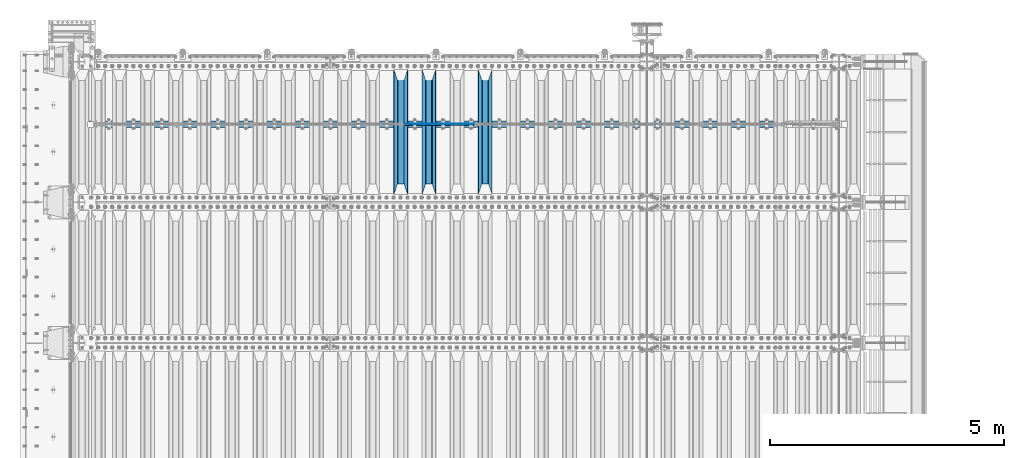
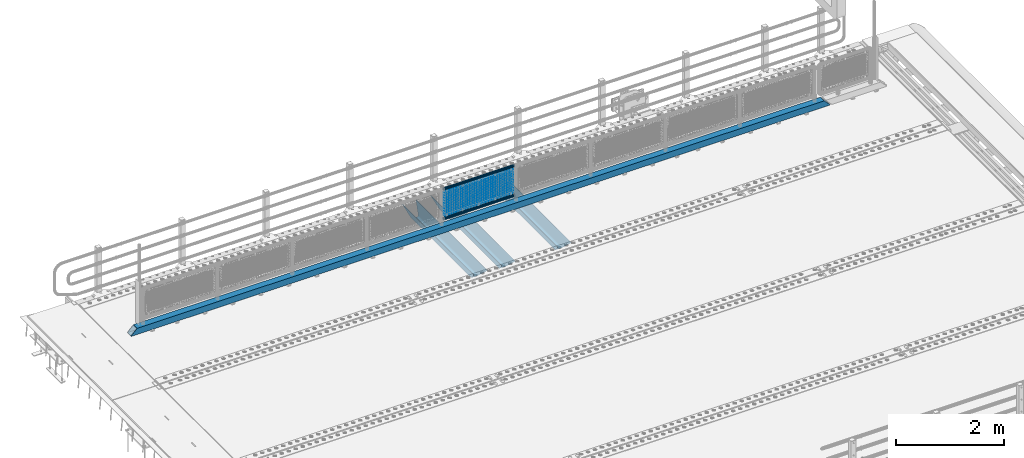
# One storey, part 122 of 257: 23 beams.
"""IFC2X3 building model written with IfcOpenShell, lengths in millimetres."""

import ifcopenshell
import ifcopenshell.guid

model = None  # the IFC model being written
_history = None  # IfcOwnerHistory: only IFC2X3 demands one
_inside = {}  # id of a spatial element -> (the spatial element, [elements in it])
_under = {}  # id of a project, library or spatial element -> (it, [spatial elements below it])
_declared = {}  # id of a project -> (the project, [libraries it declares])
_typed = {}  # id of a type object -> (the type object, [elements of that type])
_made_of = {}  # id of a material, layer set ... -> (it, [elements and type objects made of it])


def new_model(schema):
    """Start an empty IFC model of exactly this schema.

    Asked for "IFC4X3", IfcOpenShell would pick the latest addendum, in which some entities
    have other attributes; the version numbers below select the first issue.
    IFC2X3 requires an IfcOwnerHistory on every rooted entity: one is made here for all.
    """
    global model, _history
    if schema == "IFC4X3":
        model = ifcopenshell.file(schema_version=(4, 3, 0, 0))
    else:
        model = ifcopenshell.file(schema=schema)
    _inside.clear()
    _under.clear()
    _declared.clear()
    _typed.clear()
    _made_of.clear()
    _history = None
    if model.schema == "IFC2X3":
        org = make("IfcOrganization", Name="unknown")
        user = make(
            "IfcPersonAndOrganization",
            ThePerson=make("IfcPerson", FamilyName="unknown"),
            TheOrganization=org,
        )
        app = make(
            "IfcApplication",
            ApplicationDeveloper=org,
            Version="unknown",
            ApplicationFullName="unknown",
            ApplicationIdentifier="unknown",
        )
        _history = make(
            "IfcOwnerHistory",
            OwningUser=user,
            OwningApplication=app,
            ChangeAction="ADDED",
            CreationDate=0,
        )
    return model


def make(cls, **values):
    """One entity of the class cls with the attributes given. An attribute that is None is left unset."""
    return model.create_entity(
        cls, **{name: value for name, value in values.items() if value is not None}
    )


def rooted(cls, **values):
    """An entity with a GlobalId (a new one), such as an element, a storey or a relation."""
    return make(cls, GlobalId=ifcopenshell.guid.new(), OwnerHistory=_history, **values)


def si_unit(unit_type, name, prefix=None):
    """IfcSIUnit, for example si_unit("LENGTHUNIT", "METRE", prefix="MILLI")."""
    return make("IfcSIUnit", UnitType=unit_type, Prefix=prefix, Name=name)


def assignment(units):
    """IfcUnitAssignment: the units of a project."""
    return None if units is None else make("IfcUnitAssignment", Units=units)


def point(xyz):
    """IfcCartesianPoint."""
    return None if xyz is None else make("IfcCartesianPoint", Coordinates=xyz)


def direction(xyz):
    """IfcDirection."""
    return None if xyz is None else make("IfcDirection", DirectionRatios=xyz)


def frame(location, z_axis=None, x_axis=None):
    """IfcAxis2Placement3D, a coordinate frame: its origin and axes. An axis left out is left unset."""
    return make(
        "IfcAxis2Placement3D",
        Location=point(location),
        Axis=direction(z_axis),
        RefDirection=direction(x_axis),
    )


def origin_with_axes():
    """The frame at (0, 0, 0) with the z axis (0, 0, 1) and the x axis (1, 0, 0) written out."""
    return frame((0.0, 0.0, 0.0), z_axis=(0.0, 0.0, 1.0), x_axis=(1.0, 0.0, 0.0))


def place(relative_to, where):
    """IfcLocalPlacement: puts the frame where relative to a parent placement (None: the world)."""
    return make(
        "IfcLocalPlacement", PlacementRelTo=relative_to, RelativePlacement=where
    )


def context(
    kind, dimensions, precision=None, world=None, true_north=None, identifier=None
):
    """IfcGeometricRepresentationContext, for example the 3D "Model" context."""
    return make(
        "IfcGeometricRepresentationContext",
        ContextIdentifier=identifier,
        ContextType=kind,
        CoordinateSpaceDimension=dimensions,
        Precision=precision,
        WorldCoordinateSystem=world,
        TrueNorth=true_north,
    )


def subcontext(parent, identifier, kind, view, scale=None):
    """IfcGeometricRepresentationSubContext, for example "Body" below "Model"."""
    return make(
        "IfcGeometricRepresentationSubContext",
        ContextIdentifier=identifier,
        ContextType=kind,
        ParentContext=parent,
        TargetScale=scale,
        TargetView=view,
    )


def project(units=None, contexts=None):
    """IfcProject with its units and contexts."""
    return rooted(
        "IfcProject",
        Name="project",
        RepresentationContexts=contexts,
        UnitsInContext=assignment(units),
    )


def spatial(cls, under=None, at=None, **own):
    """A site, building, storey or space (cls), placed at a placement, below another one or the project."""
    s = rooted(cls, ObjectPlacement=at, **own)
    if under is not None:
        _under.setdefault(under.id(), (under, []))[1].append(s)
    return s


def faces_of(points, faces, orient=None, outer=None):
    """IfcFace entities. A face is a list of loops; a loop is a list of indices into points, from 0.

    orient and outer hold one flag for each loop. By default every Orientation is true, the
    first loop of a face is its IfcFaceOuterBound and the others are IfcFaceBound.
    """
    made = []
    for i, loops in enumerate(faces):
        bounds = []
        for j, loop in enumerate(loops):
            is_outer = j == 0 if outer is None else outer[i][j]
            bounds.append(
                make(
                    "IfcFaceOuterBound" if is_outer else "IfcFaceBound",
                    Bound=make("IfcPolyLoop", Polygon=[points[k] for k in loop]),
                    Orientation=True if orient is None else orient[i][j],
                )
            )
        made.append(make("IfcFace", Bounds=bounds))
    return made


def faceted_brep(points, faces, orient=None, outer=None, voids=None):
    """IfcFacetedBrep: a solid bounded by flat faces; with voids (closed shells), ...WithVoids."""
    shared = [point(p) for p in points]
    hull = make("IfcClosedShell", CfsFaces=faces_of(shared, faces, orient, outer))
    if voids is None:
        return make("IfcFacetedBrep", Outer=hull)
    return make(
        "IfcFacetedBrepWithVoids",
        Outer=hull,
        Voids=[
            make(cls, CfsFaces=faces_of(shared, fs, o, b)) for cls, fs, o, b in voids
        ],
    )


def shape(context_of_items, identifier, shape_type, items):
    """IfcShapeRepresentation: the items that make up one representation, for example the "Body"."""
    return make(
        "IfcShapeRepresentation",
        ContextOfItems=context_of_items,
        RepresentationIdentifier=identifier,
        RepresentationType=shape_type,
        Items=items,
    )


def material(Name=None, Category=None):
    """IfcMaterial."""
    return make("IfcMaterial", Name=Name, Category=Category)


def made_of(thing, what):
    """Note that an element or type object is made of a material, layer set ...; save() writes the relation."""
    if what is not None:
        _made_of.setdefault(what.id(), (what, []))[1].append(thing)
    return thing


def type_object(cls, material=None, **own):
    """A type object (cls), such as IfcWallType, which elements share."""
    return made_of(rooted(cls, **own), material)


def element(
    cls,
    number,
    at=None,
    inside=None,
    cuts=None,
    type_object=None,
    material=None,
    context=None,
    identifier="Body",
    shape_type=None,
    held_by="IfcProductDefinitionShape",
    body=None,
    shapes=None,
    **own,
):
    """One element of the class cls, such as IfcWall. Its Tag is "e" and its number.

    at: its placement. inside: the storey or other place that contains it. cuts: it is an
    opening in that element (IfcRelVoidsElement). A single representation is given by context,
    identifier, shape_type and body (its items); several are given by shapes. held_by: the class
    of the entity that holds the representations. save() writes the other relations.
    """
    e = rooted(cls, Tag="e%d" % number, ObjectPlacement=at, **own)
    if body is not None:
        shapes = [shape(context, identifier, shape_type, body)]
    if shapes is not None:
        e.Representation = make(held_by, Representations=shapes)
    if inside is not None:
        _inside.setdefault(inside.id(), (inside, []))[1].append(e)
    if cuts is not None:
        rooted(
            "IfcRelVoidsElement", RelatingBuildingElement=cuts, RelatedOpeningElement=e
        )
    if type_object is not None:
        _typed.setdefault(type_object.id(), (type_object, []))[1].append(e)
    return made_of(e, material)


def aggregate(whole, parts):
    """IfcRelAggregates: a whole, such as a stair, and the parts it consists of."""
    return rooted("IfcRelAggregates", RelatingObject=whole, RelatedObjects=parts)


def save(model, path):
    """Write the relations noted so far, then the file.

    IfcRelAggregates (storeys below a building ...), IfcRelContainedInSpatialStructure (elements
    in a storey), IfcRelDefinesByType, IfcRelAssociatesMaterial and IfcRelDeclares: one each for
    every whole, place, type object, material and project.
    """
    for whole, parts in _under.values():
        aggregate(whole, parts)
    for where, things in _inside.values():
        rooted(
            "IfcRelContainedInSpatialStructure",
            RelatedElements=things,
            RelatingStructure=where,
        )
    for kind, things in _typed.values():
        rooted("IfcRelDefinesByType", RelatedObjects=things, RelatingType=kind)
    for what, things in _made_of.values():
        rooted("IfcRelAssociatesMaterial", RelatedObjects=things, RelatingMaterial=what)
    for by, libraries in _declared.values():
        rooted("IfcRelDeclares", RelatingContext=by, RelatedDefinitions=libraries)
    model.write(path)


model = new_model("IFC2X3")

# Units and contexts
model_context = context("Model", 3, precision=1e-05, world=origin_with_axes())
body_context = subcontext(model_context, "Body", "Model", "MODEL_VIEW")
ifc_project = project(units=[si_unit("LENGTHUNIT", "METRE", prefix="MILLI"), si_unit("AREAUNIT", "SQUARE_METRE"), si_unit("VOLUMEUNIT", "CUBIC_METRE"), si_unit("MASSUNIT", "GRAM", prefix="KILO"), si_unit("TIMEUNIT", "SECOND"), si_unit("PLANEANGLEUNIT", "RADIAN"), si_unit("SOLIDANGLEUNIT", "STERADIAN"), si_unit("THERMODYNAMICTEMPERATUREUNIT", "DEGREE_CELSIUS"), si_unit("LUMINOUSINTENSITYUNIT", "LUMEN")], contexts=[model_context])

# Site, building, storey
site_placement = place(None, origin_with_axes())
site = spatial("IfcSite", under=ifc_project, at=site_placement, CompositionType="ELEMENT")
building_placement = place(site_placement, origin_with_axes())
building = spatial("IfcBuilding", under=site, at=building_placement, Name="Standard", CompositionType="ELEMENT")
storey_placement = place(building_placement, origin_with_axes())
storey = spatial("IfcBuildingStorey", under=building, at=storey_placement, Name="Undefined", CompositionType="ELEMENT", Elevation=0.0)

# Beams
ifc_material_1 = material(Name="STEEL/S355N")
beam_type_1 = type_object("IfcBeamType", PredefinedType="NOTDEFINED")
beam_1_placement = place(storey_placement, frame((51250.0, 9175.0, -115.0), z_axis=(0.0, 0.0, 1.0), x_axis=(0.0, 1.0, 0.0)))
element("IfcBeam", 1, at=beam_1_placement, inside=storey, type_object=beam_type_1, material=ifc_material_1, context=body_context, shape_type="Brep", body=[
    faceted_brep([(0.0, 150.0, 115.0), (0.0, 143.690000000002, 115.0), (2650.00000000297, 143.690000000002, 115.0), (2650.00000000297, 150.0, 115.0), (2650.00000000297, 142.059565218406, 110.0000000031), (2650.00000000297, 148.369565218403, 110.0000000031), (2441.90079219208, -80.1103600731149, -98.0992078077845), (2437.7588105432, -77.5672621345584, -102.241189456673), (2434.06523489746, -74.4080125315522, -105.934765102404), (2430.91086095089, -70.7102721255724, -109.089139048974), (2428.37322971128, -66.5649389910031, -111.626770288588), (2426.51472138055, -62.0739139532889, -113.485278619323), (2425.38102192091, -57.3475956567636, -114.618978078955), (2424.99999999987, -52.5021667386536, -115.0), (2424.99999999987, 52.5021667386536, -115.0), (2425.38102192091, 57.3475956567636, -114.618978078955), (2426.51472138055, 62.0739139532889, -113.485278619323), (2428.37322971128, 66.5649389910031, -111.626770288588), (2430.91086095089, 70.7102721255724, -109.089139048974), (2434.06523489746, 74.4080125315522, -105.934765102404), (2437.7588105432, 77.5672621345584, -102.241189456673), (2441.90079219208, 80.1103600731149, -98.0992078077846), (2446.38936140511, 81.9747917625791, -93.6106385947584), (2448.24948500409, 76.2713538057287, -91.7505149957729), (2444.62967112262, 74.76777986261, -95.3703288772456), (2441.28936334126, 72.7168944282894, -98.710636658607), (2438.31067330438, 70.1691124903809, -101.689326695487), (2435.76682334747, 67.1870637758839, -104.233176652398), (2433.72034654133, 63.8440531834931, -106.279653458539), (2432.22154950041, 60.2222587982324, -107.778450499454), (2431.30727574265, 56.4107117849126, -108.692724257221), (2430.99999999987, 52.5031078186876, -109.0), (2430.99999999987, -52.5031078186876, -109.0), (2431.30727574265, -56.4107117849126, -108.692724257221), (2432.22154950041, -60.2222587982324, -107.778450499454), (2433.72034654133, -63.8440531834931, -106.279653458539), (2435.76682334747, -67.1870637758839, -104.233176652398), (2438.31067330438, -70.1691124903809, -101.689326695487), (2441.28936334126, -72.7168944282894, -98.7106366586071), (2444.62967112262, -74.76777986261, -95.3703288772457), (2448.24948500409, -76.2713538057287, -91.7505149957729), (2650.00000000297, -142.059565218406, 110.0000000031), (2650.00000000297, -148.369565218403, 110.0000000031), (2446.38936140511, -81.9747917625791, -93.6106385947584), (2650.00000000297, -143.690000000002, 115.0), (2650.00000000297, -150.0, 115.0), (0.0, -143.690000000002, 115.0), (0.0, -150.0, 115.0), (0.0, -148.369565218258, 110.000000002662), (203.61063859742, -81.9747917625791, -93.6106385947584), (208.099207810447, -80.1103600731149, -98.0992078077845), (212.241189459335, -77.5672621345584, -102.241189456673), (215.934765105066, -74.4080125315522, -105.934765102404), (219.089139051636, -70.7102721255724, -109.089139048974), (221.626770291251, -66.5649389910031, -111.626770288588), (223.485278621985, -62.0739139532889, -113.485278619323), (224.618978081617, -57.3475956567636, -114.618978078955), (225.000000002662, -52.5021667386536, -115.0), (225.000000002662, 52.5021667386536, -115.0), (224.618978081617, 57.3475956567636, -114.618978078955), (223.485278621985, 62.0739139532889, -113.485278619323), (221.626770291251, 66.5649389910031, -111.626770288588), (219.089139051636, 70.7102721255724, -109.089139048974), (215.934765105066, 74.4080125315522, -105.934765102404), (212.241189459335, 77.5672621345584, -102.241189456673), (208.099207810447, 80.1103600731149, -98.0992078077846), (203.61063859742, 81.9747917625791, -93.6106385947584), (0.0, 148.369565218258, 110.000000002662), (0.0, 142.05956521826, 110.000000002662), (201.750514998435, 76.2713538057287, -91.7505149957729), (205.370328879908, 74.76777986261, -95.3703288772456), (208.710636661269, 72.7168944282894, -98.710636658607), (211.689326698149, 70.1691124903809, -101.689326695487), (214.233176655061, 67.1870637758839, -104.233176652398), (216.279653461201, 63.8440531834931, -106.279653458539), (217.778450502116, 60.2222587982324, -107.778450499454), (218.692724259884, 56.4107117849126, -108.692724257221), (219.000000002662, 52.5031078186876, -109.0), (219.000000002662, -52.5031078186876, -109.0), (218.692724259884, -56.4107117849126, -108.692724257221), (217.778450502116, -60.2222587982324, -107.778450499454), (216.279653461201, -63.8440531834931, -106.279653458539), (214.233176655061, -67.1870637758839, -104.233176652398), (211.689326698149, -70.1691124903809, -101.689326695487), (208.710636661269, -72.7168944282894, -98.7106366586071), (205.370328879908, -74.76777986261, -95.3703288772457), (201.750514998435, -76.2713538057287, -91.7505149957729), (0.0, -142.05956521826, 110.000000002662)], [[[0, 1, 2, 3]], [[3, 2, 4, 5]], [[6, 7, 8, 9, 10, 11, 12, 13, 14, 15, 16, 17, 18, 19, 20, 21, 22, 5, 4, 23, 24, 25, 26, 27, 28, 29, 30, 31, 32, 33, 34, 35, 36, 37, 38, 39, 40, 41, 42, 43]], [[44, 45, 42, 41]], [[46, 47, 45, 44]], [[43, 42, 45, 47, 48, 49]], [[6, 43, 49, 50]], [[7, 6, 50, 51]], [[8, 7, 51, 52]], [[9, 8, 52, 53]], [[10, 9, 53, 54]], [[11, 10, 54, 55]], [[12, 11, 55, 56]], [[13, 12, 56, 57]], [[14, 13, 57, 58]], [[15, 14, 58, 59]], [[16, 15, 59, 60]], [[17, 16, 60, 61]], [[18, 17, 61, 62]], [[19, 18, 62, 63]], [[20, 19, 63, 64]], [[21, 20, 64, 65]], [[22, 21, 65, 66]], [[0, 3, 5, 22, 66, 67]], [[1, 0, 67, 68]], [[23, 4, 2, 1, 68, 69]], [[24, 23, 69, 70]], [[25, 24, 70, 71]], [[26, 25, 71, 72]], [[27, 26, 72, 73]], [[28, 27, 73, 74]], [[29, 28, 74, 75]], [[30, 29, 75, 76]], [[31, 30, 76, 77]], [[32, 31, 77, 78]], [[33, 32, 78, 79]], [[34, 33, 79, 80]], [[35, 34, 80, 81]], [[36, 35, 81, 82]], [[37, 36, 82, 83]], [[38, 37, 83, 84]], [[39, 38, 84, 85]], [[40, 39, 85, 86]], [[46, 44, 41, 40, 86, 87]], [[47, 46, 87, 48]], [[86, 85, 84, 83, 82, 81, 80, 79, 78, 77, 76, 75, 74, 73, 72, 71, 70, 69, 68, 67, 66, 65, 64, 63, 62, 61, 60, 59, 58, 57, 56, 55, 54, 53, 52, 51, 50, 49, 48, 87]]]),
])
beam_2_placement = place(storey_placement, frame((50050.0, 9175.0, -115.0), z_axis=(0.0, 0.0, 1.0), x_axis=(0.0, 1.0, 0.0)))
element("IfcBeam", 2, at=beam_2_placement, inside=storey, type_object=beam_type_1, material=ifc_material_1, context=body_context, shape_type="Brep", body=[
    faceted_brep([(0.0, 150.0, 115.0), (0.0, 143.690000000002, 115.0), (2650.00000000297, 143.690000000002, 115.0), (2650.00000000297, 150.0, 115.0), (2650.00000000297, 142.059565218406, 110.0000000031), (2650.00000000297, 148.369565218403, 110.0000000031), (2441.90079219208, -80.1103600731149, -98.0992078077845), (2437.7588105432, -77.5672621345584, -102.241189456673), (2434.06523489746, -74.4080125315522, -105.934765102404), (2430.91086095089, -70.7102721255724, -109.089139048974), (2428.37322971128, -66.5649389910031, -111.626770288588), (2426.51472138055, -62.0739139532889, -113.485278619323), (2425.38102192091, -57.3475956567636, -114.618978078955), (2424.99999999987, -52.5021667386536, -115.0), (2424.99999999987, 52.5021667386536, -115.0), (2425.38102192091, 57.3475956567636, -114.618978078955), (2426.51472138055, 62.0739139532889, -113.485278619323), (2428.37322971128, 66.5649389910031, -111.626770288588), (2430.91086095089, 70.7102721255724, -109.089139048974), (2434.06523489746, 74.4080125315522, -105.934765102404), (2437.7588105432, 77.5672621345584, -102.241189456673), (2441.90079219208, 80.1103600731149, -98.0992078077846), (2446.38936140511, 81.9747917625791, -93.6106385947584), (2448.24948500409, 76.2713538057287, -91.7505149957729), (2444.62967112262, 74.76777986261, -95.3703288772456), (2441.28936334126, 72.7168944282894, -98.710636658607), (2438.31067330438, 70.1691124903809, -101.689326695487), (2435.76682334747, 67.1870637758839, -104.233176652398), (2433.72034654133, 63.8440531834931, -106.279653458539), (2432.22154950041, 60.2222587982324, -107.778450499454), (2431.30727574265, 56.4107117849126, -108.692724257221), (2430.99999999987, 52.5031078186876, -109.0), (2430.99999999987, -52.5031078186876, -109.0), (2431.30727574265, -56.4107117849126, -108.692724257221), (2432.22154950041, -60.2222587982324, -107.778450499454), (2433.72034654133, -63.8440531834931, -106.279653458539), (2435.76682334747, -67.1870637758839, -104.233176652398), (2438.31067330438, -70.1691124903809, -101.689326695487), (2441.28936334126, -72.7168944282894, -98.7106366586071), (2444.62967112262, -74.76777986261, -95.3703288772457), (2448.24948500409, -76.2713538057287, -91.7505149957729), (2650.00000000297, -142.059565218406, 110.0000000031), (2650.00000000297, -148.369565218403, 110.0000000031), (2446.38936140511, -81.9747917625791, -93.6106385947584), (2650.00000000297, -143.690000000002, 115.0), (2650.00000000297, -150.0, 115.0), (0.0, -143.690000000002, 115.0), (0.0, -150.0, 115.0), (0.0, -148.369565218258, 110.000000002662), (203.61063859742, -81.9747917625791, -93.6106385947584), (208.099207810447, -80.1103600731149, -98.0992078077845), (212.241189459335, -77.5672621345584, -102.241189456673), (215.934765105066, -74.4080125315522, -105.934765102404), (219.089139051636, -70.7102721255724, -109.089139048974), (221.626770291251, -66.5649389910031, -111.626770288588), (223.485278621985, -62.0739139532889, -113.485278619323), (224.618978081617, -57.3475956567636, -114.618978078955), (225.000000002662, -52.5021667386536, -115.0), (225.000000002662, 52.5021667386536, -115.0), (224.618978081617, 57.3475956567636, -114.618978078955), (223.485278621985, 62.0739139532889, -113.485278619323), (221.626770291251, 66.5649389910031, -111.626770288588), (219.089139051636, 70.7102721255724, -109.089139048974), (215.934765105066, 74.4080125315522, -105.934765102404), (212.241189459335, 77.5672621345584, -102.241189456673), (208.099207810447, 80.1103600731149, -98.0992078077846), (203.61063859742, 81.9747917625791, -93.6106385947584), (0.0, 148.369565218258, 110.000000002662), (0.0, 142.05956521826, 110.000000002662), (201.750514998435, 76.2713538057287, -91.7505149957729), (205.370328879908, 74.76777986261, -95.3703288772456), (208.710636661269, 72.7168944282894, -98.710636658607), (211.689326698149, 70.1691124903809, -101.689326695487), (214.233176655061, 67.1870637758839, -104.233176652398), (216.279653461201, 63.8440531834931, -106.279653458539), (217.778450502116, 60.2222587982324, -107.778450499454), (218.692724259884, 56.4107117849126, -108.692724257221), (219.000000002662, 52.5031078186876, -109.0), (219.000000002662, -52.5031078186876, -109.0), (218.692724259884, -56.4107117849126, -108.692724257221), (217.778450502116, -60.2222587982324, -107.778450499454), (216.279653461201, -63.8440531834931, -106.279653458539), (214.233176655061, -67.1870637758839, -104.233176652398), (211.689326698149, -70.1691124903809, -101.689326695487), (208.710636661269, -72.7168944282894, -98.7106366586071), (205.370328879908, -74.76777986261, -95.3703288772457), (201.750514998435, -76.2713538057287, -91.7505149957729), (0.0, -142.05956521826, 110.000000002662)], [[[0, 1, 2, 3]], [[3, 2, 4, 5]], [[6, 7, 8, 9, 10, 11, 12, 13, 14, 15, 16, 17, 18, 19, 20, 21, 22, 5, 4, 23, 24, 25, 26, 27, 28, 29, 30, 31, 32, 33, 34, 35, 36, 37, 38, 39, 40, 41, 42, 43]], [[44, 45, 42, 41]], [[46, 47, 45, 44]], [[43, 42, 45, 47, 48, 49]], [[6, 43, 49, 50]], [[7, 6, 50, 51]], [[8, 7, 51, 52]], [[9, 8, 52, 53]], [[10, 9, 53, 54]], [[11, 10, 54, 55]], [[12, 11, 55, 56]], [[13, 12, 56, 57]], [[14, 13, 57, 58]], [[15, 14, 58, 59]], [[16, 15, 59, 60]], [[17, 16, 60, 61]], [[18, 17, 61, 62]], [[19, 18, 62, 63]], [[20, 19, 63, 64]], [[21, 20, 64, 65]], [[22, 21, 65, 66]], [[0, 3, 5, 22, 66, 67]], [[1, 0, 67, 68]], [[23, 4, 2, 1, 68, 69]], [[24, 23, 69, 70]], [[25, 24, 70, 71]], [[26, 25, 71, 72]], [[27, 26, 72, 73]], [[28, 27, 73, 74]], [[29, 28, 74, 75]], [[30, 29, 75, 76]], [[31, 30, 76, 77]], [[32, 31, 77, 78]], [[33, 32, 78, 79]], [[34, 33, 79, 80]], [[35, 34, 80, 81]], [[36, 35, 81, 82]], [[37, 36, 82, 83]], [[38, 37, 83, 84]], [[39, 38, 84, 85]], [[40, 39, 85, 86]], [[46, 44, 41, 40, 86, 87]], [[47, 46, 87, 48]], [[86, 85, 84, 83, 82, 81, 80, 79, 78, 77, 76, 75, 74, 73, 72, 71, 70, 69, 68, 67, 66, 65, 64, 63, 62, 61, 60, 59, 58, 57, 56, 55, 54, 53, 52, 51, 50, 49, 48, 87]]]),
])
beam_3_placement = place(storey_placement, frame((49450.0, 9175.0, -115.0), z_axis=(0.0, 0.0, 1.0), x_axis=(0.0, 1.0, 0.0)))
element("IfcBeam", 3, at=beam_3_placement, inside=storey, type_object=beam_type_1, material=ifc_material_1, context=body_context, shape_type="Brep", body=[
    faceted_brep([(0.0, 150.0, 115.0), (0.0, 143.690000000002, 115.0), (2650.00000000297, 143.690000000002, 115.0), (2650.00000000297, 150.0, 115.0), (2650.00000000297, 142.059565218406, 110.0000000031), (2650.00000000297, 148.369565218403, 110.0000000031), (2441.90079219208, -80.1103600731149, -98.0992078077845), (2437.7588105432, -77.5672621345584, -102.241189456673), (2434.06523489746, -74.4080125315522, -105.934765102404), (2430.91086095089, -70.7102721255724, -109.089139048974), (2428.37322971128, -66.5649389910031, -111.626770288588), (2426.51472138055, -62.0739139532889, -113.485278619323), (2425.38102192091, -57.3475956567636, -114.618978078955), (2424.99999999987, -52.5021667386536, -115.0), (2424.99999999987, 52.5021667386536, -115.0), (2425.38102192091, 57.3475956567636, -114.618978078955), (2426.51472138055, 62.0739139532889, -113.485278619323), (2428.37322971128, 66.5649389910031, -111.626770288588), (2430.91086095089, 70.7102721255724, -109.089139048974), (2434.06523489746, 74.4080125315522, -105.934765102404), (2437.7588105432, 77.5672621345584, -102.241189456673), (2441.90079219208, 80.1103600731149, -98.0992078077846), (2446.38936140511, 81.9747917625791, -93.6106385947584), (2448.24948500409, 76.2713538057287, -91.7505149957729), (2444.62967112262, 74.76777986261, -95.3703288772456), (2441.28936334126, 72.7168944282894, -98.710636658607), (2438.31067330438, 70.1691124903809, -101.689326695487), (2435.76682334747, 67.1870637758839, -104.233176652398), (2433.72034654133, 63.8440531834931, -106.279653458539), (2432.22154950041, 60.2222587982324, -107.778450499454), (2431.30727574265, 56.4107117849126, -108.692724257221), (2430.99999999987, 52.5031078186876, -109.0), (2430.99999999987, -52.5031078186876, -109.0), (2431.30727574265, -56.4107117849126, -108.692724257221), (2432.22154950041, -60.2222587982324, -107.778450499454), (2433.72034654133, -63.8440531834931, -106.279653458539), (2435.76682334747, -67.1870637758839, -104.233176652398), (2438.31067330438, -70.1691124903809, -101.689326695487), (2441.28936334126, -72.7168944282894, -98.7106366586071), (2444.62967112262, -74.76777986261, -95.3703288772457), (2448.24948500409, -76.2713538057287, -91.7505149957729), (2650.00000000297, -142.059565218406, 110.0000000031), (2650.00000000297, -148.369565218403, 110.0000000031), (2446.38936140511, -81.9747917625791, -93.6106385947584), (2650.00000000297, -143.690000000002, 115.0), (2650.00000000297, -150.0, 115.0), (0.0, -143.690000000002, 115.0), (0.0, -150.0, 115.0), (0.0, -148.369565218258, 110.000000002662), (203.61063859742, -81.9747917625791, -93.6106385947584), (208.099207810447, -80.1103600731149, -98.0992078077845), (212.241189459335, -77.5672621345584, -102.241189456673), (215.934765105066, -74.4080125315522, -105.934765102404), (219.089139051636, -70.7102721255724, -109.089139048974), (221.626770291251, -66.5649389910031, -111.626770288588), (223.485278621985, -62.0739139532889, -113.485278619323), (224.618978081617, -57.3475956567636, -114.618978078955), (225.000000002662, -52.5021667386536, -115.0), (225.000000002662, 52.5021667386536, -115.0), (224.618978081617, 57.3475956567636, -114.618978078955), (223.485278621985, 62.0739139532889, -113.485278619323), (221.626770291251, 66.5649389910031, -111.626770288588), (219.089139051636, 70.7102721255724, -109.089139048974), (215.934765105066, 74.4080125315522, -105.934765102404), (212.241189459335, 77.5672621345584, -102.241189456673), (208.099207810447, 80.1103600731149, -98.0992078077846), (203.61063859742, 81.9747917625791, -93.6106385947584), (0.0, 148.369565218258, 110.000000002662), (0.0, 142.05956521826, 110.000000002662), (201.750514998435, 76.2713538057287, -91.7505149957729), (205.370328879908, 74.76777986261, -95.3703288772456), (208.710636661269, 72.7168944282894, -98.710636658607), (211.689326698149, 70.1691124903809, -101.689326695487), (214.233176655061, 67.1870637758839, -104.233176652398), (216.279653461201, 63.8440531834931, -106.279653458539), (217.778450502116, 60.2222587982324, -107.778450499454), (218.692724259884, 56.4107117849126, -108.692724257221), (219.000000002662, 52.5031078186876, -109.0), (219.000000002662, -52.5031078186876, -109.0), (218.692724259884, -56.4107117849126, -108.692724257221), (217.778450502116, -60.2222587982324, -107.778450499454), (216.279653461201, -63.8440531834931, -106.279653458539), (214.233176655061, -67.1870637758839, -104.233176652398), (211.689326698149, -70.1691124903809, -101.689326695487), (208.710636661269, -72.7168944282894, -98.7106366586071), (205.370328879908, -74.76777986261, -95.3703288772457), (201.750514998435, -76.2713538057287, -91.7505149957729), (0.0, -142.05956521826, 110.000000002662)], [[[0, 1, 2, 3]], [[3, 2, 4, 5]], [[6, 7, 8, 9, 10, 11, 12, 13, 14, 15, 16, 17, 18, 19, 20, 21, 22, 5, 4, 23, 24, 25, 26, 27, 28, 29, 30, 31, 32, 33, 34, 35, 36, 37, 38, 39, 40, 41, 42, 43]], [[44, 45, 42, 41]], [[46, 47, 45, 44]], [[43, 42, 45, 47, 48, 49]], [[6, 43, 49, 50]], [[7, 6, 50, 51]], [[8, 7, 51, 52]], [[9, 8, 52, 53]], [[10, 9, 53, 54]], [[11, 10, 54, 55]], [[12, 11, 55, 56]], [[13, 12, 56, 57]], [[14, 13, 57, 58]], [[15, 14, 58, 59]], [[16, 15, 59, 60]], [[17, 16, 60, 61]], [[18, 17, 61, 62]], [[19, 18, 62, 63]], [[20, 19, 63, 64]], [[21, 20, 64, 65]], [[22, 21, 65, 66]], [[0, 3, 5, 22, 66, 67]], [[1, 0, 67, 68]], [[23, 4, 2, 1, 68, 69]], [[24, 23, 69, 70]], [[25, 24, 70, 71]], [[26, 25, 71, 72]], [[27, 26, 72, 73]], [[28, 27, 73, 74]], [[29, 28, 74, 75]], [[30, 29, 75, 76]], [[31, 30, 76, 77]], [[32, 31, 77, 78]], [[33, 32, 78, 79]], [[34, 33, 79, 80]], [[35, 34, 80, 81]], [[36, 35, 81, 82]], [[37, 36, 82, 83]], [[38, 37, 83, 84]], [[39, 38, 84, 85]], [[40, 39, 85, 86]], [[46, 44, 41, 40, 86, 87]], [[47, 46, 87, 48]], [[86, 85, 84, 83, 82, 81, 80, 79, 78, 77, 76, 75, 74, 73, 72, 71, 70, 69, 68, 67, 66, 65, 64, 63, 62, 61, 60, 59, 58, 57, 56, 55, 54, 53, 52, 51, 50, 49, 48, 87]]]),
])
ifc_material_2 = material()
beam_type_2 = type_object("IfcBeamType", PredefinedType="NOTDEFINED")
beam_4_placement = place(storey_placement, frame((42775.0, 10664.5, 98.0199999999977), z_axis=(0.0, 0.0, 1.0), x_axis=(1.0, 0.0, 0.0)))
element("IfcBeam", 4, at=beam_4_placement, inside=storey, type_object=beam_type_2, material=ifc_material_2, context=body_context, shape_type="Brep", body=[
    faceted_brep([(0.0, -70.0, -70.0), (0.0, 70.0, -70.0), (14992.0, 70.0, -70.0), (14992.0, -70.0, -70.0), (14861.8884698478, -70.0, 70.0), (14861.8884698478, 70.0, 70.0), (130.111530936141, 70.0, 70.0), (130.111528976144, -70.0, 70.0), (14992.0, -70.0, -60.0079600980695), (0.0, -70.0, -60.0079591069104), (14871.8964362873, -60.0, 60.0), (14992.0, -60.0, -60.0), (0.0, -60.0, -60.0), (120.103562690863, -60.0, 60.0), (14871.8964362873, 60.0, 60.0), (120.10356437086, 60.0, 60.0), (14992.0, 60.0, -60.0), (0.0, 60.0, -60.0), (14992.0, 70.0, -60.0079600980695), (0.0, 70.0, -60.007961065347)], [[[0, 1, 2, 3]], [[4, 5, 6, 7]], [[0, 3, 8, 4, 7, 9]], [[10, 11, 12, 13]], [[14, 10, 13, 15]], [[16, 14, 15, 17]], [[4, 8, 11, 10, 14, 16, 18, 5]], [[11, 8, 3, 2, 18, 16]], [[17, 12, 11, 16]], [[1, 0, 9, 12, 17, 19]], [[5, 18, 2, 1, 19, 6]], [[17, 15, 13, 12, 9, 7, 6, 19]]]),
])
ifc_material_3 = material(Name="Misc_Undefined")
beam_type_3 = type_object("IfcBeamType", Name="D3", PredefinedType="NOTDEFINED")
for number, where, z_axis, x_axis in (
    (5, (49526.0, 10670.5, 851.597000000002), (0.0, 0.0, 1.0), (1.0, 0.0, 0.0)),
    (6, (49526.0, 10670.5, 669.452000000002), (0.0, 0.0, 1.0), (1.0, 0.0, 0.0)),
    (7, (49526.0, 10670.5, 523.736000000002), (0.0, 0.0, 1.0), (1.0, 0.0, 0.0)),
    (8, (49526.0, 10670.5, 487.307000000002), (0.0, 0.0, 1.0), (1.0, 0.0, 0.0)),
    (9, (49526.0, 10670.5, 705.881000000002), (0.0, 0.0, 1.0), (1.0, 0.0, 0.0)),
    (10, (49526.0, 10670.5, 596.594000000002), (0.0, 0.0, 1.0), (1.0, 0.0, 0.0)),
    (11, (49526.0, 10670.5, 450.878000000002), (0.0, 0.0, 1.0), (1.0, 0.0, 0.0)),
    (12, (49526.0, 10670.5, 815.168000000002), (0.0, 0.0, 1.0), (1.0, 0.0, 0.0)),
    (13, (49526.0, 10670.5, 888.026000000002), (0.0, 0.0, 1.0), (1.0, 0.0, 0.0)),
    (14, (49526.0, 10670.5, 778.739000000002), (0.0, 0.0, 1.0), (1.0, 0.0, 0.0)),
    (15, (49526.0, 10670.5, 742.310000000002), (0.0, 0.0, 1.0), (1.0, 0.0, 0.0)),
    (16, (49526.0, 10670.5, 633.023000000002), (0.0, 0.0, 1.0), (1.0, 0.0, 0.0)),
    (17, (49526.0, 10670.5, 560.165000000002), (0.0, 0.0, 1.0), (1.0, 0.0, 0.0)),
    (18, (49526.0, 10670.5, 414.449000000002), (0.0, 0.0, 1.0), (1.0, 0.0, 0.0)),
):
    element("IfcBeam", number, at=place(storey_placement, frame(where, z_axis=z_axis, x_axis=x_axis)), inside=storey, type_object=beam_type_3, material=ifc_material_3, ObjectType="D3", context=body_context, shape_type="Brep", body=[
        faceted_brep([(0.0, -1.5, -5.6843418860808e-14), (0.0, -0.750000000001819, -1.29903810567669), (1490.0, -0.75, -1.29903810567669), (1490.0, -1.5, 0.0), (7.27595761418343e-12, 0.749999999998181, -1.29903810567669), (1490.0, 0.75, -1.29903810567669), (0.0, 1.5, -5.6843418860808e-14), (1490.0, 1.5, 0.0), (7.27595761418343e-12, 0.749999999998181, 1.29903810567669), (1490.0, 0.75, 1.29903810567669), (0.0, -0.750000000001819, 1.29903810567669), (1490.0, -0.75, 1.29903810567669)], [[[0, 1, 2, 3]], [[1, 4, 5, 2]], [[4, 6, 7, 5]], [[6, 8, 9, 7]], [[8, 10, 11, 9]], [[10, 0, 3, 11]], [[5, 7, 9, 11, 3, 2]], [[10, 8, 6, 4, 1, 0]]]),
    ])
beam_5_placement = place(storey_placement, frame((49551.0, 10670.5, 353.020000000002), z_axis=(0.0, 0.0, 1.0), x_axis=(1.0, 0.0, 0.0)))
element("IfcBeam", 19, at=beam_5_placement, inside=storey, type_object=beam_type_3, material=ifc_material_3, ObjectType="D3", context=body_context, shape_type="Brep", body=[
    faceted_brep([(0.0, -1.5, -5.6843418860808e-14), (0.0, -0.750000000001819, -1.29903810567669), (1440.0, -0.75, -1.29903810567669), (1440.0, -1.5, 0.0), (7.27595761418343e-12, 0.749999999998181, -1.29903810567669), (1440.0, 0.75, -1.29903810567663), (0.0, 1.5, -5.6843418860808e-14), (1440.0, 1.5, 0.0), (7.27595761418343e-12, 0.749999999998181, 1.29903810567669), (1440.0, 0.75, 1.29903810567669), (0.0, -0.750000000001819, 1.29903810567669), (1440.0, -0.75, 1.29903810567669)], [[[0, 1, 2, 3]], [[1, 4, 5, 2]], [[4, 6, 7, 5]], [[6, 8, 9, 7]], [[8, 10, 11, 9]], [[10, 0, 3, 11]], [[5, 7, 9, 11, 3, 2]], [[10, 8, 6, 4, 1, 0]]]),
])
beam_6_placement = place(storey_placement, frame((49526.0, 10670.5, 378.020000000002), z_axis=(0.0, 0.0, 1.0), x_axis=(1.0, 0.0, 0.0)))
element("IfcBeam", 20, at=beam_6_placement, inside=storey, type_object=beam_type_3, material=ifc_material_3, ObjectType="D3", context=body_context, shape_type="Brep", body=[
    faceted_brep([(0.0, -1.5, -5.6843418860808e-14), (0.0, -0.750000000001819, -1.29903810567669), (1490.0, -0.75, -1.29903810567669), (1490.0, -1.5, 0.0), (7.27595761418343e-12, 0.749999999998181, -1.29903810567669), (1490.0, 0.75, -1.29903810567669), (0.0, 1.5, -5.6843418860808e-14), (1490.0, 1.5, 0.0), (7.27595761418343e-12, 0.749999999998181, 1.29903810567669), (1490.0, 0.75, 1.29903810567669), (0.0, -0.750000000001819, 1.29903810567669), (1490.0, -0.75, 1.29903810567669)], [[[0, 1, 2, 3]], [[1, 4, 5, 2]], [[4, 6, 7, 5]], [[6, 8, 9, 7]], [[8, 10, 11, 9]], [[10, 0, 3, 11]], [[5, 7, 9, 11, 3, 2]], [[10, 8, 6, 4, 1, 0]]]),
])
beam_7_placement = place(storey_placement, frame((49551.0, 10670.5, 913.020000000002), z_axis=(0.0, 0.0, 1.0), x_axis=(1.0, 0.0, 0.0)))
element("IfcBeam", 21, at=beam_7_placement, inside=storey, type_object=beam_type_3, material=ifc_material_3, ObjectType="D3", context=body_context, shape_type="Brep", body=[
    faceted_brep([(0.0, -1.5, -5.6843418860808e-14), (0.0, -0.750000000001819, -1.29903810567669), (1440.0, -0.75, -1.29903810567669), (1440.0, -1.5, 0.0), (7.27595761418343e-12, 0.749999999998181, -1.29903810567669), (1440.0, 0.75, -1.29903810567663), (0.0, 1.5, -5.6843418860808e-14), (1440.0, 1.5, 0.0), (7.27595761418343e-12, 0.749999999998181, 1.29903810567669), (1440.0, 0.75, 1.29903810567669), (0.0, -0.750000000001819, 1.29903810567669), (1440.0, -0.75, 1.29903810567669)], [[[0, 1, 2, 3]], [[1, 4, 5, 2]], [[4, 6, 7, 5]], [[6, 8, 9, 7]], [[8, 10, 11, 9]], [[10, 0, 3, 11]], [[5, 7, 9, 11, 3, 2]], [[10, 8, 6, 4, 1, 0]]]),
])
beam_type_4 = type_object("IfcBeamType", PredefinedType="NOTDEFINED")
beam_8_placement = place(storey_placement, frame((49505.85, 10664.5, 298.170000000003), z_axis=(0.0, 0.0, 1.0), x_axis=(1.0, 0.0, 0.0)))
element("IfcBeam", 22, at=beam_8_placement, inside=storey, type_object=beam_type_4, material=ifc_material_2, context=body_context, shape_type="Brep", body=[
    faceted_brep([(0.0, -25.3500000000004, 0.0), (0.0, -23.4203461491616, 9.70102501045767), (1530.0, -23.4203461491616, 9.70102501045506), (1530.0, -25.3500000000004, 0.0), (0.0, -17.9251569030785, 17.9251569030821), (1530.0, -17.9251569030785, 17.925156903079), (0.0, -9.70102501045585, 23.4203461491634), (1530.0, -9.70102501045585, 23.4203461491611), (0.0, 0.0, 25.3499999999985), (1530.0, 0.0, 25.35), (0.0, 9.70102501045585, 23.4203461491634), (1530.0, 9.70102501045585, 23.4203461491611), (0.0, 17.9251569030785, 17.9251569030821), (1530.0, 17.9251569030785, 17.925156903079), (0.0, 23.4203461491616, 9.70102501045767), (1530.0, 23.4203461491616, 9.701025010455), (0.0, 25.3500000000004, 0.0), (1530.0, 25.3500000000004, 0.0), (0.0, 23.4203461491616, -9.70102501045767), (1530.0, 23.4203461491616, -9.70102501045506), (0.0, 17.9251569030785, -17.9251569030821), (1530.0, 17.9251569030785, -17.925156903079), (0.0, 9.70102501045585, -23.4203461491634), (1530.0, 9.70102501045585, -23.4203461491611), (0.0, 0.0, -25.3499999999985), (1530.0, 0.0, -25.35), (0.0, -9.70102501045585, -23.4203461491634), (1530.0, -9.70102501045585, -23.4203461491611), (0.0, -17.9251569030785, -17.9251569030821), (1530.0, -17.9251569030785, -17.925156903079), (0.0, -23.4203461491616, -9.70102501045767), (1530.0, -23.4203461491616, -9.701025010455), (0.0, -30.1499999999996, 0.0), (0.0, -27.8549679052157, -11.5379054858058), (1530.0, -27.8549679052157, -11.5379054858075), (1530.0, -30.1499999999996, 0.0), (0.0, -21.3192694527752, -21.3192694527752), (1530.0, -21.3192694527752, -21.3192694527744), (0.0, -11.5379054858076, -27.8549679052157), (1530.0, -11.5379054858076, -27.8549679052153), (0.0, 0.0, -30.1500000000015), (1530.0, 0.0, -30.15), (0.0, 11.5379054858076, -27.8549679052157), (1530.0, 11.5379054858076, -27.8549679052153), (0.0, 21.3192694527752, -21.3192694527752), (1530.0, 21.3192694527752, -21.3192694527744), (0.0, 27.8549679052157, -11.5379054858058), (1530.0, 27.8549679052157, -11.5379054858075), (0.0, 30.1499999999996, 0.0), (1530.0, 30.1499999999996, 0.0), (0.0, 27.8549679052157, 11.5379054858058), (1530.0, 27.8549679052157, 11.5379054858075), (0.0, 21.3192694527752, 21.3192694527752), (1530.0, 21.3192694527752, 21.3192694527744), (0.0, 11.5379054858076, 27.8549679052157), (1530.0, 11.5379054858076, 27.8549679052153), (0.0, 0.0, 30.1500000000015), (1530.0, 0.0, 30.15), (0.0, -11.5379054858076, 27.8549679052157), (1530.0, -11.5379054858076, 27.8549679052153), (0.0, -21.3192694527752, 21.3192694527752), (1530.0, -21.3192694527752, 21.3192694527744), (0.0, -27.8549679052157, 11.5379054858058), (1530.0, -27.8549679052157, 11.5379054858075)], [[[0, 1, 2, 3]], [[1, 4, 5, 2]], [[4, 6, 7, 5]], [[6, 8, 9, 7]], [[8, 10, 11, 9]], [[10, 12, 13, 11]], [[12, 14, 15, 13]], [[14, 16, 17, 15]], [[16, 18, 19, 17]], [[18, 20, 21, 19]], [[20, 22, 23, 21]], [[22, 24, 25, 23]], [[24, 26, 27, 25]], [[26, 28, 29, 27]], [[28, 30, 31, 29]], [[30, 0, 3, 31]], [[32, 33, 34, 35]], [[33, 36, 37, 34]], [[36, 38, 39, 37]], [[38, 40, 41, 39]], [[40, 42, 43, 41]], [[42, 44, 45, 43]], [[44, 46, 47, 45]], [[46, 48, 49, 47]], [[48, 50, 51, 49]], [[50, 52, 53, 51]], [[52, 54, 55, 53]], [[54, 56, 57, 55]], [[56, 58, 59, 57]], [[58, 60, 61, 59]], [[60, 62, 63, 61]], [[62, 32, 35, 63]], [[37, 39, 41, 43, 45, 47, 49, 51, 53, 55, 57, 59, 61, 63, 35, 34], [5, 7, 9, 11, 13, 15, 17, 19, 21, 23, 25, 27, 29, 31, 3, 2]], [[62, 60, 58, 56, 54, 52, 50, 48, 46, 44, 42, 40, 38, 36, 33, 32], [30, 28, 26, 24, 22, 20, 18, 16, 14, 12, 10, 8, 6, 4, 1, 0]]]),
])
beam_9_placement = place(storey_placement, frame((49505.85, 10664.5, 969.850000000002), z_axis=(0.0, 0.0, 1.0), x_axis=(1.0, 0.0, 0.0)))
element("IfcBeam", 23, at=beam_9_placement, inside=storey, type_object=beam_type_4, material=ifc_material_2, context=body_context, shape_type="Brep", body=[
    faceted_brep([(0.0, -25.3500000000004, 0.0), (0.0, -23.4203461491616, 9.70102501045767), (1530.0, -23.4203461491616, 9.70102501045506), (1530.0, -25.3500000000004, 0.0), (0.0, -17.9251569030785, 17.9251569030821), (1530.0, -17.9251569030785, 17.925156903079), (0.0, -9.70102501045585, 23.4203461491634), (1530.0, -9.70102501045585, 23.4203461491611), (0.0, 0.0, 25.3499999999985), (1530.0, 0.0, 25.35), (0.0, 9.70102501045585, 23.4203461491634), (1530.0, 9.70102501045585, 23.4203461491611), (0.0, 17.9251569030785, 17.9251569030821), (1530.0, 17.9251569030785, 17.925156903079), (0.0, 23.4203461491616, 9.70102501045767), (1530.0, 23.4203461491616, 9.701025010455), (0.0, 25.3500000000004, 0.0), (1530.0, 25.3500000000004, 0.0), (0.0, 23.4203461491616, -9.70102501045767), (1530.0, 23.4203461491616, -9.70102501045506), (0.0, 17.9251569030785, -17.9251569030821), (1530.0, 17.9251569030785, -17.925156903079), (0.0, 9.70102501045585, -23.4203461491634), (1530.0, 9.70102501045585, -23.4203461491611), (0.0, 0.0, -25.3499999999985), (1530.0, 0.0, -25.35), (0.0, -9.70102501045585, -23.4203461491634), (1530.0, -9.70102501045585, -23.4203461491611), (0.0, -17.9251569030785, -17.9251569030821), (1530.0, -17.9251569030785, -17.925156903079), (0.0, -23.4203461491616, -9.70102501045767), (1530.0, -23.4203461491616, -9.701025010455), (0.0, -30.1499999999996, 0.0), (0.0, -27.8549679052157, -11.5379054858058), (1530.0, -27.8549679052157, -11.5379054858075), (1530.0, -30.1499999999996, 0.0), (0.0, -21.3192694527752, -21.3192694527752), (1530.0, -21.3192694527752, -21.3192694527744), (0.0, -11.5379054858076, -27.8549679052157), (1530.0, -11.5379054858076, -27.8549679052153), (0.0, 0.0, -30.1500000000015), (1530.0, 0.0, -30.15), (0.0, 11.5379054858076, -27.8549679052157), (1530.0, 11.5379054858076, -27.8549679052153), (0.0, 21.3192694527752, -21.3192694527752), (1530.0, 21.3192694527752, -21.3192694527744), (0.0, 27.8549679052157, -11.5379054858058), (1530.0, 27.8549679052157, -11.5379054858075), (0.0, 30.1499999999996, 0.0), (1530.0, 30.1499999999996, 0.0), (0.0, 27.8549679052157, 11.5379054858058), (1530.0, 27.8549679052157, 11.5379054858075), (0.0, 21.3192694527752, 21.3192694527752), (1530.0, 21.3192694527752, 21.3192694527744), (0.0, 11.5379054858076, 27.8549679052157), (1530.0, 11.5379054858076, 27.8549679052153), (0.0, 0.0, 30.1500000000015), (1530.0, 0.0, 30.15), (0.0, -11.5379054858076, 27.8549679052157), (1530.0, -11.5379054858076, 27.8549679052153), (0.0, -21.3192694527752, 21.3192694527752), (1530.0, -21.3192694527752, 21.3192694527744), (0.0, -27.8549679052157, 11.5379054858058), (1530.0, -27.8549679052157, 11.5379054858075)], [[[0, 1, 2, 3]], [[1, 4, 5, 2]], [[4, 6, 7, 5]], [[6, 8, 9, 7]], [[8, 10, 11, 9]], [[10, 12, 13, 11]], [[12, 14, 15, 13]], [[14, 16, 17, 15]], [[16, 18, 19, 17]], [[18, 20, 21, 19]], [[20, 22, 23, 21]], [[22, 24, 25, 23]], [[24, 26, 27, 25]], [[26, 28, 29, 27]], [[28, 30, 31, 29]], [[30, 0, 3, 31]], [[32, 33, 34, 35]], [[33, 36, 37, 34]], [[36, 38, 39, 37]], [[38, 40, 41, 39]], [[40, 42, 43, 41]], [[42, 44, 45, 43]], [[44, 46, 47, 45]], [[46, 48, 49, 47]], [[48, 50, 51, 49]], [[50, 52, 53, 51]], [[52, 54, 55, 53]], [[54, 56, 57, 55]], [[56, 58, 59, 57]], [[58, 60, 61, 59]], [[60, 62, 63, 61]], [[62, 32, 35, 63]], [[37, 39, 41, 43, 45, 47, 49, 51, 53, 55, 57, 59, 61, 63, 35, 34], [5, 7, 9, 11, 13, 15, 17, 19, 21, 23, 25, 27, 29, 31, 3, 2]], [[62, 60, 58, 56, 54, 52, 50, 48, 46, 44, 42, 40, 38, 36, 33, 32], [30, 28, 26, 24, 22, 20, 18, 16, 14, 12, 10, 8, 6, 4, 1, 0]]]),
])

save(model, "model.ifc")
